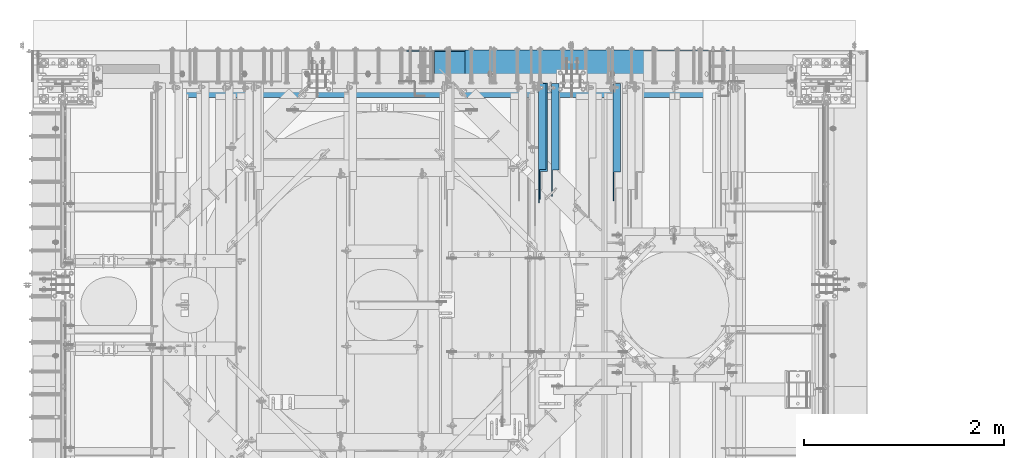
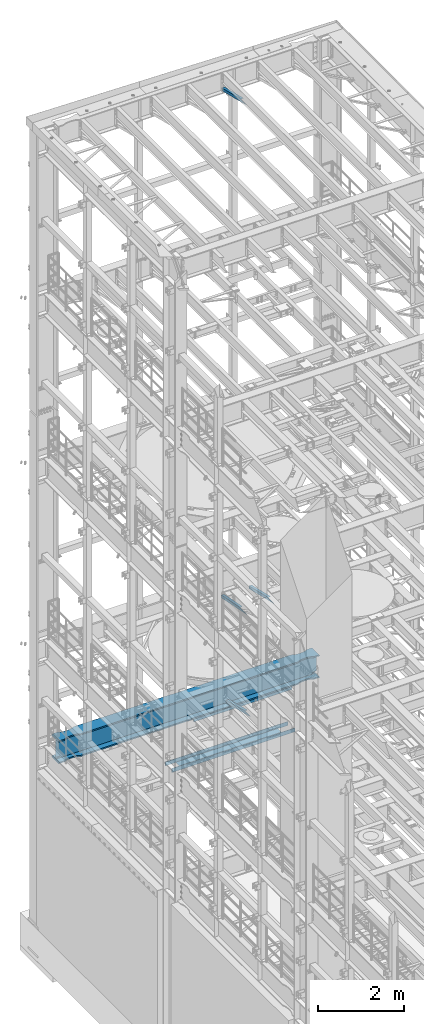
# One storey, part 1068 of 1876: 7 beams, 7 elements without a shape of their own.
"""IFC2X3 building model written with IfcOpenShell, lengths in millimetres."""

from ifc_helpers import new_model, si_unit, frame, origin_with_axes, place, context, subcontext, project, spatial, faceted_brep, material, type_object, element, aggregate, save


model = new_model("IFC2X3")

# Units and contexts
model_context = context("Model", 3, precision=1e-05, world=origin_with_axes())
body_context = subcontext(model_context, "Body", "Model", "MODEL_VIEW")
ifc_project = project(units=[si_unit("LENGTHUNIT", "METRE", prefix="MILLI"), si_unit("AREAUNIT", "SQUARE_METRE"), si_unit("VOLUMEUNIT", "CUBIC_METRE"), si_unit("MASSUNIT", "GRAM", prefix="KILO"), si_unit("TIMEUNIT", "SECOND"), si_unit("PLANEANGLEUNIT", "RADIAN"), si_unit("SOLIDANGLEUNIT", "STERADIAN"), si_unit("THERMODYNAMICTEMPERATUREUNIT", "DEGREE_CELSIUS"), si_unit("LUMINOUSINTENSITYUNIT", "LUMEN")], contexts=[model_context])

# Site, building, storey
site_placement = place(None, origin_with_axes())
site = spatial("IfcSite", under=ifc_project, at=site_placement, CompositionType="ELEMENT")
building_placement = place(site_placement, origin_with_axes())
building = spatial("IfcBuilding", under=site, at=building_placement, Name="Undefined", CompositionType="ELEMENT")
storey_placement = place(building_placement, origin_with_axes())
storey = spatial("IfcBuildingStorey", under=building, at=storey_placement, Name="Undefined", CompositionType="ELEMENT", Elevation=0.0)

# Assembly, beam
assembly_1_placement = place(storey_placement, origin_with_axes())
assembly_1 = element("IfcElementAssembly", 1, at=assembly_1_placement, inside=storey, AssemblyPlace="NOTDEFINED", PredefinedType="RIGID_FRAME")
ifc_material_1 = material(Name="STEEL/A36")
beam_type_1 = type_object("IfcBeamType", Name="L3X3X3/8", PredefinedType="NOTDEFINED")
beam_1_placement = place(assembly_1_placement, frame((4914.90000009537, 12830.5843372416, 4789.15168871849), z_axis=(1.0, 0.0, 0.0), x_axis=(0.0, 0.967147277703794, -0.254216724922142)))
beam_1 = element("IfcBeam", 2, at=beam_1_placement, type_object=beam_type_1, material=ifc_material_1, ObjectType="L3X3X3/8", context=body_context, shape_type="Brep", body=[
    faceted_brep([(24.9786869882064, 38.1000000000076, -38.1000000000004), (24.9786869882064, 38.1000000000076, 38.1000000000004), (881.684520949349, 38.1000000001804, 38.1000000000004), (881.684520949349, 38.1000000001804, -38.1000000000004), (-11.2584166993365, 28.5749999999989, 38.1000000000004), (881.696433462228, 28.5750000001808, 38.1000000000004), (-11.2584166993365, 28.5749999999989, -28.5749999999998), (881.696433462228, 28.5750000001808, -28.5749999999998), (-264.91814251215, -38.1000000000549, -28.5749999999998), (881.779821052378, -38.0999999998203, -28.5749999999998), (-264.91814251215, -38.1000000000549, -38.1000000000004), (881.779821052378, -38.0999999998203, -38.1000000000004)], [[[0, 1, 2, 3]], [[1, 4, 5, 2]], [[4, 6, 7, 5]], [[6, 8, 9, 7]], [[8, 10, 11, 9]], [[10, 0, 3, 11]], [[5, 7, 9, 11, 3, 2]], [[10, 8, 6, 4, 1, 0]]]),
])
aggregate(assembly_1, [beam_1])

assembly_2_placement = place(storey_placement, origin_with_axes())
assembly_2 = element("IfcElementAssembly", 3, at=assembly_2_placement, inside=storey, AssemblyPlace="NOTDEFINED", PredefinedType="RIGID_FRAME")
beam_2_placement = place(assembly_2_placement, frame((4797.425, 12840.8509533049, 22213.431722183), z_axis=(1.0, 0.0, 0.0), x_axis=(0.0, 0.970296005691371, -0.241920774923053)))
beam_2 = element("IfcBeam", 4, at=beam_2_placement, type_object=beam_type_1, material=ifc_material_1, ObjectType="L3X3X3/8", context=body_context, shape_type="Brep", body=[
    faceted_brep([(0.0, 38.1000000000004, -38.1), (0.0, 38.1000000000004, 38.1), (871.989692018896, 38.1000000003733, 38.1000000000004), (871.989692018896, 38.1000000003733, -38.1000000000004), (-38.2028763666676, 28.5750000000298, 38.1000000000004), (871.9896920189, 28.5750000003572, 38.1000000000004), (-38.2028763666676, 28.5750000000298, -28.5749999999998), (871.9896920189, 28.5750000003572, -28.5749999999998), (-305.623010913256, -38.1000000001623, -28.5749999999998), (871.989692018928, -38.0999999997366, -28.5749999999998), (-305.623010913256, -38.1000000001623, -38.1000000000004), (871.989692018928, -38.0999999997366, -38.1000000000004)], [[[0, 1, 2, 3]], [[1, 4, 5, 2]], [[4, 6, 7, 5]], [[6, 8, 9, 7]], [[8, 10, 11, 9]], [[10, 0, 3, 11]], [[5, 7, 9, 11, 3, 2]], [[10, 8, 6, 4, 1, 0]]]),
])
aggregate(assembly_2, [beam_2])

assembly_3_placement = place(storey_placement, origin_with_axes())
assembly_3 = element("IfcElementAssembly", 5, at=assembly_3_placement, inside=storey, AssemblyPlace="NOTDEFINED", PredefinedType="RIGID_FRAME")
beam_3_placement = place(assembly_3_placement, frame((4783.93125, 12872.1857065717, 7766.82651976129), z_axis=(1.0, 0.0, 0.0), x_axis=(0.0, 0.979618903835331, -0.200865136966236)))
beam_3 = element("IfcBeam", 6, at=beam_3_placement, type_object=beam_type_1, material=ifc_material_1, ObjectType="L3X3X3/8", context=body_context, shape_type="Brep", body=[
    faceted_brep([(0.0, 38.1000000000004, -38.1), (0.0, 38.1000000000004, 38.1), (830.060116754295, 38.1000000001277, 38.0999999999999), (830.060116754295, 38.1000000001277, -38.0999999999999), (-46.4534075084157, 28.5749999999953, 38.0999999999999), (830.060116754288, 28.5750000001281, 38.0999999999999), (-46.4534075084157, 28.5749999999953, -28.575), (830.060116754288, 28.5750000001281, -28.575), (-371.627259972192, -38.1000000000549, -28.575), (830.060116754226, -38.0999999998749, -28.575), (-371.627259972192, -38.1000000000549, -38.0999999999999), (830.060116754226, -38.0999999998749, -38.0999999999999)], [[[0, 1, 2, 3]], [[1, 4, 5, 2]], [[4, 6, 7, 5]], [[6, 8, 9, 7]], [[8, 10, 11, 9]], [[10, 0, 3, 11]], [[5, 7, 9, 11, 3, 2]], [[10, 8, 6, 4, 1, 0]]]),
])
aggregate(assembly_3, [beam_3])

assembly_4_placement = place(storey_placement, origin_with_axes())
assembly_4 = element("IfcElementAssembly", 7, at=assembly_4_placement, inside=storey, AssemblyPlace="NOTDEFINED", PredefinedType="RIGID_FRAME")
beam_4_placement = place(assembly_4_placement, frame((5527.675, 12840.0279763324, 7802.01022141264), z_axis=(1.0, 0.0, 0.0), x_axis=(0.0, 0.972828834357878, -0.231525504085172)))
beam_4 = element("IfcBeam", 8, at=beam_4_placement, type_object=beam_type_1, material=ifc_material_1, ObjectType="L3X3X3/8", context=body_context, shape_type="Brep", body=[
    faceted_brep([(0.0, 38.1000000000004, -38.1), (0.0, 38.1000000000004, 38.1), (867.661726641916, 38.1000000002095, 38.1000000000004), (867.661726641916, 38.1000000002095, -38.1000000000004), (-40.0223495126247, 28.5749999999825, 38.1000000000004), (867.584845052073, 28.5750000002117, 38.1000000000004), (-40.0223495126247, 28.5749999999825, -28.5749999999998), (867.584845052073, 28.5750000002117, -28.5749999999998), (-320.178796151862, -38.1000000000677, -28.5749999999998), (867.04667392318, -38.0999999997694, -28.5749999999998), (-320.178796151862, -38.1000000000677, -38.1000000000004), (867.04667392318, -38.0999999997694, -38.1000000000004)], [[[0, 1, 2, 3]], [[1, 4, 5, 2]], [[4, 6, 7, 5]], [[6, 8, 9, 7]], [[8, 10, 11, 9]], [[10, 0, 3, 11]], [[5, 7, 9, 11, 3, 2]], [[10, 8, 6, 4, 1, 0]]]),
])
aggregate(assembly_4, [beam_4])

assembly_5_placement = place(storey_placement, origin_with_axes())
assembly_5 = element("IfcElementAssembly", 9, at=assembly_5_placement, inside=storey, Name="BENT PLATE", AssemblyPlace="NOTDEFINED", PredefinedType="RIGID_FRAME")
beam_type_2 = type_object("IfcBeamType", PredefinedType="NOTDEFINED")
beam_5_placement = place(assembly_5_placement, frame((5334.00001220702, 14017.625, 4279.90000305175), z_axis=(1.0, 0.0, 0.0), x_axis=(0.0, 0.0, 1.0)))
beam_5 = element("IfcBeam", 10, at=beam_5_placement, type_object=beam_type_2, material=ifc_material_1, Name="BENT PLATE", context=body_context, shape_type="Brep", body=[
    faceted_brep([(0.0, -6.35000000000036, -1320.8), (0.0, -6.35000000000036, 1320.8), (0.0, 6.35000000000036, 1320.8), (0.0, 6.35000000000036, -1320.8), (190.499996948253, 6.35000000000218, 1320.8), (190.499996948253, 6.35000000000218, -1320.8), (203.199996948254, -6.34999999999854, -1320.8), (203.199996948254, -6.34999999999854, 1320.8), (190.499996948253, 303.212481689452, 1320.8), (190.499996948253, 303.212481689452, -1320.8), (203.199996948254, 315.912481689453, -1320.8), (203.199996948254, 315.912481689453, 1320.8), (2.45563569478691e-11, 303.212481689452, 1320.8), (2.45563569478691e-11, 303.212481689452, -1320.8), (2.45563569478691e-11, 315.912481689453, 1320.8), (2.45563569478691e-11, 315.912481689453, -1320.8)], [[[0, 1, 2, 3]], [[3, 2, 4, 5]], [[1, 0, 6, 7]], [[5, 4, 8, 9]], [[7, 6, 10, 11]], [[9, 8, 12, 13]], [[8, 4, 2, 1, 7, 11, 14, 12]], [[11, 10, 15, 14]], [[10, 6, 0, 3, 5, 9, 13, 15]], [[14, 15, 13, 12]]]),
])
aggregate(assembly_5, [beam_5])

assembly_6_placement = place(storey_placement, origin_with_axes())
assembly_6 = element("IfcElementAssembly", 11, at=assembly_6_placement, inside=storey, Name="BENT PLATE", AssemblyPlace="NOTDEFINED", PredefinedType="RIGID_FRAME")
beam_type_3 = type_object("IfcBeamType", PredefinedType="NOTDEFINED")
beam_6_placement = place(assembly_6_placement, frame((5079.99995117187, 14016.0375, 3159.12500000004), z_axis=(1.0, 0.0, 0.0), x_axis=(0.0, 0.0, -1.0)))
beam_6 = element("IfcBeam", 12, at=beam_6_placement, type_object=beam_type_3, material=ifc_material_1, Name="BENT PLATE", context=body_context, shape_type="Brep", body=[
    faceted_brep([(111.124998474122, -4.76250610351599, 1651.0), (101.599998474122, -4.76250000000073, 1651.0), (101.599998474122, -4.76250000000073, 1371.59995155207), (111.124998474122, -4.76249995652506, 1371.59995150444), (101.599998474122, -301.624987792969, 1371.59994502117), (111.124998474122, -301.624987749541, 1371.59994497354), (111.124998474122, -301.624993896485, 1650.99999990518), (101.599998474122, -301.624987792969, 1651.0), (0.0, -4.76250000000073, -1651.0), (0.0, -4.76250000000073, -1371.59995061689), (0.0, -4.76250000000073, 1371.59995206011), (0.0, -4.76250000000073, 1651.0), (0.0, 4.76250000000073, 1651.0), (0.0, 4.76250000000073, -1651.0), (111.124998474122, 4.76250000000073, 1651.0), (111.124998474122, 4.76250000000073, -1651.0), (111.124998474122, -4.76250606001486, -1651.0), (101.599998474122, -4.76250000000073, -1651.0), (111.124998474122, -4.76251220700578, -1371.5999511725), (101.599998474122, -4.76250000000073, -1371.59995112488), (111.124998474122, -301.624999999975, -1371.5999512195), (101.599998474122, -301.624987792969, -1371.59995117187), (111.124998474122, -301.624993853029, -1651.0), (101.599998474122, -301.624987792969, -1651.0), (111.124998474122, -311.149987792971, -1651.0), (0.0, -311.149987792971, -1651.0), (0.0, -301.624987792969, -1651.0), (0.0, -301.624987792969, 1651.0), (0.0, -311.149987792971, 1651.0), (111.124998474122, -311.149987792971, 1651.0), (0.0, -301.624987792969, 1371.59994552921), (0.0, -301.624987792969, -1371.59995066388)], [[[0, 1, 2, 3]], [[3, 2, 4, 5]], [[6, 5, 4, 7]], [[8, 9, 10, 11, 12, 13]], [[13, 12, 14, 15]], [[8, 13, 15, 16, 17]], [[18, 19, 17, 16]], [[20, 21, 19, 18]], [[22, 23, 21, 20]], [[24, 25, 26, 23, 22]], [[27, 28, 29, 6, 7]], [[24, 29, 28, 25]], [[27, 30, 31, 26, 25, 28]], [[7, 4, 21, 23, 26, 31, 30, 27]], [[19, 21, 4, 2]], [[11, 10, 9, 8, 17, 19, 2, 1]], [[14, 12, 11, 1, 0]], [[29, 24, 22, 20, 18, 16, 15, 14, 0, 3, 5, 6]]]),
])
aggregate(assembly_6, [beam_6])

assembly_7_placement = place(storey_placement, origin_with_axes())
assembly_7 = element("IfcElementAssembly", 13, at=assembly_7_placement, inside=storey, Name="BEAM", AssemblyPlace="NOTDEFINED", PredefinedType="RIGID_FRAME")
ifc_material_2 = material(Name="STEEL/A992")
beam_type_4 = type_object("IfcBeamType", Name="W24X192", PredefinedType="NOTDEFINED")
beam_7_placement = place(assembly_7_placement, frame((0.0, 13716.0, 4806.95), z_axis=(0.0, 0.0, 1.0), x_axis=(1.0, 0.0, 0.0)))
beam_7 = element("IfcBeam", 14, at=beam_7_placement, type_object=beam_type_4, material=ifc_material_2, Name="BEAM", ObjectType="W24X192", context=body_context, shape_type="Brep", body=[
    faceted_brep([(7305.675, 10.3187500000004, 234.9495), (7318.375, -10.3187500000004, 234.9495), (7318.375, -10.3187500000004, -234.9495), (7305.675, 10.3187500000004, -234.9495), (314.325, 10.3187500000004, -234.9495), (301.625, -10.3187500000004, -234.9495), (301.625, -10.3187500000004, 234.9495), (314.325, 10.3187500000004, 234.9495), (7318.375, -165.1, 287.3375), (7318.375, -10.3187500000004, 287.3375), (7318.375, 10.3187500000004, 287.3375), (7318.375, 165.1, 287.3375), (7297.29441686758, 165.10000015544, 323.85), (7297.29441686758, -165.10000015544, 323.85), (7162.79999999997, 165.100001147153, 323.85), (7162.79999999997, 165.1, 287.3375), (7106.74278259149, 137.743354635527, 287.3375), (7106.74278259149, 137.743354635527, 323.85), (7106.31195150567, 137.548767822031, 287.3375), (7106.31195150567, 137.548767822031, 323.85), (7105.87030058721, 137.380173875744, 287.3375), (7105.87030058721, 137.380173875744, 323.85), (7105.41939640416, 137.238170811695, 287.3375), (7105.41939640416, 137.238170811695, 323.85), (7104.96083834654, 137.123262325114, 287.3375), (7104.96083834654, 137.123262325114, 323.85), (7027.22388047199, 120.086541102203, 287.3375), (7027.22388047199, 120.086541102203, 323.85), (6946.89999542258, 114.300000048446, 287.3375), (6946.89999542258, 114.300000048446, 323.85), (6866.57611029489, 120.086540015548, 287.3375), (6866.57611029489, 120.086540015548, 323.85), (6787.91106783742, 137.326657821507, 287.3375), (6787.91106783742, 137.326657821507, 323.85), (6731.00000871489, 165.1, 287.3375), (6731.00000871489, 165.100000403941, 323.85), (888.999990590519, 165.1, 287.3375), (888.999990590519, 165.100004421514, 323.85), (832.088931467987, 137.326657821507, 287.3375), (832.088931467987, 137.326657821507, 323.85), (753.423889010533, 120.086540015548, 287.3375), (753.423889010533, 120.086540015548, 323.85), (673.100003882856, 114.300000048446, 287.3375), (673.100003882856, 114.300000048446, 323.85), (592.776118833464, 120.086541102203, 287.3375), (592.776118833464, 120.086541102203, 323.85), (515.039160958935, 137.123262325114, 287.3375), (515.039160958935, 137.123262325114, 323.85), (514.580602901315, 137.238170811695, 287.3375), (514.580602901315, 137.238170811695, 323.85), (514.12969871826, 137.380173875744, 287.3375), (514.12969871826, 137.380173875744, 323.85), (513.688047799806, 137.548767822031, 287.3375), (513.688047799806, 137.548767822031, 323.85), (513.257216713985, 137.743354635527, 287.3375), (513.257216713985, 137.743354635527, 323.85), (457.199999305522, 165.1, 287.3375), (457.199999305522, 165.1, 323.85), (301.625, 165.1, 287.3375), (322.705583132423, 165.1, 323.85), (7162.79999999997, 165.100001147153, -287.3375), (7162.79999999997, 165.1, -323.85), (7106.74278259149, 137.743354635527, -323.85), (7106.74278259149, 137.743354635527, -287.3375), (7106.31195150567, 137.548767822031, -323.85), (7106.31195150567, 137.548767822031, -287.3375), (7105.87030058721, 137.380173875744, -323.85), (7105.87030058721, 137.380173875744, -287.3375), (7105.41939640416, 137.238170811695, -323.85), (7105.41939640416, 137.238170811695, -287.3375), (7104.96083834654, 137.123262325114, -323.85), (7104.96083834654, 137.123262325114, -287.3375), (7027.22388047199, 120.086541102203, -323.85), (7027.22388047199, 120.086541102203, -287.3375), (6946.89999542258, 114.300000048446, -323.85), (6946.89999542258, 114.300000048446, -287.3375), (6866.57611029489, 120.086540015548, -323.85), (6866.57611029489, 120.086540015548, -287.3375), (6787.91106783742, 137.326657821507, -323.85), (6787.91106783742, 137.326657821507, -287.3375), (6731.00000871489, 165.1, -323.85), (6731.00000871489, 165.100000403941, -287.3375), (888.999990590519, 165.1, -323.85), (888.999990590519, 165.100004421514, -287.337500000001), (832.088931467987, 137.326657821507, -323.85), (832.088931467987, 137.326657821507, -287.3375), (753.423889010533, 120.086540015548, -323.85), (753.423889010533, 120.086540015548, -287.3375), (673.100003882856, 114.300000048446, -323.85), (673.100003882856, 114.300000048446, -287.3375), (592.776118833464, 120.086541102203, -323.85), (592.776118833464, 120.086541102203, -287.3375), (515.039160958935, 137.123262325114, -323.85), (515.039160958935, 137.123262325114, -287.3375), (514.580602901315, 137.238170811695, -323.85), (514.580602901315, 137.238170811695, -287.3375), (514.12969871826, 137.380173875744, -323.85), (514.12969871826, 137.380173875744, -287.3375), (513.688047799806, 137.548767822031, -323.85), (513.688047799806, 137.548767822031, -287.3375), (513.257216713985, 137.743354635527, -323.85), (513.257216713985, 137.743354635527, -287.3375), (457.199999305522, 165.1, -323.85), (457.199999305522, 165.1, -287.3375), (301.625, 165.1, -323.85), (322.705590767972, 165.1, -287.3375), (7162.79999999997, -165.100001147153, -287.3375), (7106.74278259149, -137.743354635527, -287.3375), (7106.74278259149, -137.743354635527, -323.85), (7162.79999999997, -165.1, -323.85), (7106.31195150567, -137.548767822031, -287.3375), (7106.31195150567, -137.548767822031, -323.85), (7105.87030058721, -137.380173875744, -287.3375), (7105.87030058721, -137.380173875744, -323.85), (7105.41939640416, -137.238170811695, -287.3375), (7105.41939640416, -137.238170811695, -323.85), (7104.96083834654, -137.123262325114, -287.3375), (7104.96083834654, -137.123262325114, -323.85), (7027.22388047199, -120.086541102203, -287.3375), (7027.22388047199, -120.086541102203, -323.85), (6946.89999542258, -114.300000048446, -287.3375), (6946.89999542258, -114.300000048446, -323.85), (6866.57611029489, -120.086540015548, -287.3375), (6866.57611029489, -120.086540015548, -323.85), (6787.91106783742, -137.326657821507, -287.3375), (6787.91106783742, -137.326657821507, -323.85), (6731.00000871489, -165.100000403941, -287.3375), (6731.00000871489, -165.1, -323.85), (888.999990590519, -165.100004421514, -287.3375), (888.999990590519, -165.1, -323.85), (832.088931467987, -137.326657821507, -287.3375), (832.088931467987, -137.326657821507, -323.85), (753.423889010533, -120.086540015548, -287.3375), (753.423889010533, -120.086540015548, -323.85), (673.100003882856, -114.300000048446, -287.3375), (673.100003882856, -114.300000048446, -323.85), (592.776118833464, -120.086541102203, -287.3375), (592.776118833464, -120.086541102203, -323.85), (515.039160958935, -137.123262325114, -287.3375), (515.039160958935, -137.123262325114, -323.85), (514.580602901315, -137.238170811695, -287.3375), (514.580602901315, -137.238170811695, -323.85), (514.12969871826, -137.380173875744, -287.3375), (514.12969871826, -137.380173875744, -323.85), (513.688047799806, -137.548767822031, -287.3375), (513.688047799806, -137.548767822031, -323.85), (513.257216713985, -137.743354635527, -287.3375), (513.257216713985, -137.743354635527, -323.85), (457.199999305522, -165.1, -287.3375), (457.199999305522, -165.1, -323.85), (322.705590767972, -165.1, -287.3375), (301.625, -165.1, -323.85), (322.934794701563, -10.3187500000004, -286.94050112915), (322.934794701563, 10.3187500000004, -286.94050112915), (322.705590767971, 10.3187500000004, -287.3375), (322.705590767971, -10.3187500000004, -287.3375), (346.976999328614, -10.3187500000004, -286.94050112915), (346.976999328614, 10.3187500000004, -286.94050112915), (420.061565494404, -10.3187500000004, -253.118738544442), (420.061565494404, 10.3187500000004, -253.118738544442), (423.945404365968, -10.3187500000004, -249.819149292641), (423.945404365968, 10.3187500000004, -249.819149292641), (425.572284211328, -10.3187500000004, -244.98957834072), (425.572284211328, 10.3187500000004, -244.98957834072), (424.476487622709, -10.3187500000004, -240.012558806176), (424.476487622709, 10.3187500000004, -240.012558806176), (420.97170190047, -10.3187500000004, -236.312833052547), (420.97170190047, 10.3187500000004, -236.312833052547), (416.061221618592, -10.3187500000004, -234.9495), (416.061221618592, 10.3187500000004, -234.9495), (415.15921904546, -10.3187500000004, 234.949499999999), (415.15921904546, 10.3187500000004, 234.949499999999), (420.069699306212, -10.3187500000004, 236.312833039836), (420.069699306212, 10.3187500000004, 236.312833039836), (423.574485026478, -10.3187500000004, 240.012558762611), (423.574485026478, 10.3187500000004, 240.012558762611), (424.670281642195, -10.3187500000004, 244.989578266865), (424.670281642195, 10.3187500000004, 244.989578266865), (423.043401848172, -10.3187500000004, 249.819149211012), (423.043401848172, 10.3187500000004, 249.819149211012), (419.159563033145, -10.3187500000004, 253.11873849267), (419.159563033145, 10.3187500000004, 253.11873849267), (346.074999237061, -10.3187500000004, 286.94050112915), (346.074999237061, 10.3187500000004, 286.94050112915), (301.625, -10.3187500000004, 286.94050112915), (301.625, 10.3187500000004, 286.94050112915), (301.625, -10.3187500000004, 287.3375), (301.625, 10.3187500000004, 287.3375), (322.705583132423, -165.1, 323.85), (301.625, -165.1, 287.3375), (457.199999305522, -165.1, 287.3375), (457.199999305522, -165.1, 323.85), (513.257216713985, -137.743354635527, 287.3375), (513.257216713985, -137.743354635527, 323.85), (513.688047799806, -137.548767822031, 287.3375), (513.688047799806, -137.548767822031, 323.85), (514.12969871826, -137.380173875744, 287.3375), (514.12969871826, -137.380173875744, 323.85), (514.580602901315, -137.238170811695, 287.3375), (514.580602901315, -137.238170811695, 323.85), (515.039160958935, -137.123262325114, 287.3375), (515.039160958935, -137.123262325114, 323.85), (592.776118833464, -120.086541102203, 287.3375), (592.776118833464, -120.086541102203, 323.85), (673.100003882856, -114.300000048446, 287.3375), (673.100003882856, -114.300000048446, 323.85), (753.423889010533, -120.086540015548, 287.3375), (753.423889010533, -120.086540015548, 323.85), (832.088931467987, -137.326657821507, 287.3375), (832.088931467987, -137.326657821507, 323.85), (888.999990590519, -165.100004421514, 323.85), (888.999990590519, -165.1, 287.3375), (6731.00000871489, -165.1, 287.3375), (6731.00000871489, -165.100000403941, 323.85), (6787.91106783742, -137.326657821507, 287.3375), (6787.91106783742, -137.326657821507, 323.85), (6866.57611029489, -120.086540015548, 287.3375), (6866.57611029489, -120.086540015548, 323.85), (6946.89999542258, -114.300000048446, 287.3375), (6946.89999542258, -114.300000048446, 323.85), (7027.22388047199, -120.086541102203, 287.3375), (7027.22388047199, -120.086541102203, 323.85), (7104.96083834654, -137.123262325114, 287.3375), (7104.96083834654, -137.123262325114, 323.85), (7105.41939640416, -137.238170811695, 287.3375), (7105.41939640416, -137.238170811695, 323.85), (7105.87030058721, -137.380173875744, 287.3375), (7105.87030058721, -137.380173875744, 323.85), (7106.31195150567, -137.548767822031, 287.3375), (7106.31195150567, -137.548767822031, 323.85), (7106.74278259149, -137.743354635527, 287.3375), (7106.74278259149, -137.743354635527, 323.85), (7162.79999999997, -165.100001147153, 323.85), (7162.79999999997, -165.1, 287.3375), (7318.375, -10.3187500000004, 286.94050112915), (7318.375, 10.3187500000004, 286.94050112915), (7273.92500076294, -10.3187500000004, 286.94050112915), (7273.92500076294, 10.3187500000004, 286.94050112915), (7200.84043696685, -10.3187500000004, 253.118738492671), (7200.84043696685, 10.3187500000004, 253.118738492671), (7196.95659815183, -10.3187500000004, 249.819149211013), (7196.95659815183, 10.3187500000004, 249.819149211013), (7195.3297183578, -10.3187500000004, 244.989578266866), (7195.3297183578, 10.3187500000004, 244.989578266866), (7196.42551497352, -10.3187500000004, 240.012558762612), (7196.42551497352, 10.3187500000004, 240.012558762612), (7199.93030069379, -10.3187500000004, 236.312833039837), (7199.93030069379, 10.3187500000004, 236.312833039837), (7204.84078095454, -10.3187500000004, 234.9495), (7204.84078095454, 10.3187500000004, 234.9495), (7203.93877838141, -10.3187500000004, -234.9495), (7203.93877838141, 10.3187500000004, -234.9495), (7199.02829809953, -10.3187500000004, -236.312833052547), (7199.02829809953, 10.3187500000004, -236.312833052547), (7195.52351237729, -10.3187500000004, -240.012558806176), (7195.52351237729, 10.3187500000004, -240.012558806176), (7194.42771578867, -10.3187500000004, -244.98957834072), (7194.42771578867, 10.3187500000004, -244.98957834072), (7196.05459563403, -10.3187500000004, -249.819149292641), (7196.05459563403, 10.3187500000004, -249.819149292641), (7199.93843450559, -10.3187500000004, -253.118738544442), (7199.93843450559, 10.3187500000004, -253.118738544442), (7273.02300067138, -10.3187500000004, -286.94050112915), (7273.02300067138, 10.3187500000004, -286.94050112915), (7297.06520529844, -10.3187500000004, -286.94050112915), (7297.06520529844, 10.3187500000004, -286.94050112915), (7297.29440923203, 10.3187500000004, -287.3375), (7297.29440923203, 165.10000015544, -287.3375), (7318.375, 165.1, -323.85), (7318.375, -165.1, -323.85), (7297.29440923203, -165.10000015544, -287.3375), (7297.29440923203, -10.3187500000004, -287.3375)], [[[0, 1, 2, 3]], [[4, 5, 6, 7]], [[8, 9, 10, 11, 12, 13]], [[14, 15, 16, 17]], [[17, 16, 18, 19]], [[19, 18, 20, 21]], [[21, 20, 22, 23]], [[23, 22, 24, 25]], [[25, 24, 26, 27]], [[27, 26, 28, 29]], [[29, 28, 30, 31]], [[31, 30, 32, 33]], [[33, 32, 34, 35]], [[36, 37, 35, 34]], [[37, 36, 38, 39]], [[39, 38, 40, 41]], [[41, 40, 42, 43]], [[43, 42, 44, 45]], [[45, 44, 46, 47]], [[47, 46, 48, 49]], [[49, 48, 50, 51]], [[51, 50, 52, 53]], [[53, 52, 54, 55]], [[55, 54, 56, 57]], [[57, 56, 58, 59]], [[60, 61, 62, 63]], [[63, 62, 64, 65]], [[65, 64, 66, 67]], [[67, 66, 68, 69]], [[69, 68, 70, 71]], [[71, 70, 72, 73]], [[73, 72, 74, 75]], [[75, 74, 76, 77]], [[77, 76, 78, 79]], [[79, 78, 80, 81]], [[82, 83, 81, 80]], [[83, 82, 84, 85]], [[85, 84, 86, 87]], [[87, 86, 88, 89]], [[89, 88, 90, 91]], [[91, 90, 92, 93]], [[93, 92, 94, 95]], [[95, 94, 96, 97]], [[97, 96, 98, 99]], [[99, 98, 100, 101]], [[101, 100, 102, 103]], [[103, 102, 104, 105]], [[106, 107, 108, 109]], [[110, 111, 108, 107]], [[112, 113, 111, 110]], [[114, 115, 113, 112]], [[116, 117, 115, 114]], [[118, 119, 117, 116]], [[120, 121, 119, 118]], [[122, 123, 121, 120]], [[124, 125, 123, 122]], [[126, 127, 125, 124]], [[128, 129, 127, 126]], [[128, 130, 131, 129]], [[132, 133, 131, 130]], [[134, 135, 133, 132]], [[136, 137, 135, 134]], [[138, 139, 137, 136]], [[140, 141, 139, 138]], [[142, 143, 141, 140]], [[144, 145, 143, 142]], [[146, 147, 145, 144]], [[148, 149, 147, 146]], [[149, 148, 150, 151]], [[152, 153, 154, 105, 104, 151, 150, 155]], [[156, 157, 153, 152]], [[158, 159, 157, 156]], [[160, 161, 159, 158]], [[162, 163, 161, 160]], [[164, 165, 163, 162]], [[166, 167, 165, 164]], [[168, 169, 167, 166]], [[169, 168, 5, 4]], [[170, 171, 7, 6]], [[172, 173, 171, 170]], [[174, 175, 173, 172]], [[176, 177, 175, 174]], [[178, 179, 177, 176]], [[180, 181, 179, 178]], [[182, 183, 181, 180]], [[183, 182, 184, 185]], [[185, 184, 186, 187]], [[188, 59, 58, 187, 186, 189]], [[190, 191, 188, 189]], [[191, 190, 192, 193]], [[193, 192, 194, 195]], [[195, 194, 196, 197]], [[197, 196, 198, 199]], [[199, 198, 200, 201]], [[201, 200, 202, 203]], [[203, 202, 204, 205]], [[205, 204, 206, 207]], [[207, 206, 208, 209]], [[210, 209, 208, 211]], [[210, 211, 212, 213]], [[213, 212, 214, 215]], [[215, 214, 216, 217]], [[217, 216, 218, 219]], [[219, 218, 220, 221]], [[221, 220, 222, 223]], [[223, 222, 224, 225]], [[225, 224, 226, 227]], [[227, 226, 228, 229]], [[229, 228, 230, 231]], [[232, 231, 230, 233]], [[232, 233, 8, 13]], [[14, 17, 19, 21, 23, 25, 27, 29, 31, 33, 35, 37, 39, 41, 43, 45, 47, 49, 51, 53, 55, 57, 59, 188, 191, 193, 195, 197, 199, 201, 203, 205, 207, 209, 210, 213, 215, 217, 219, 221, 223, 225, 227, 229, 231, 232, 13, 12]], [[15, 14, 12, 11]], [[187, 58, 56, 54, 52, 50, 48, 46, 44, 42, 40, 38, 36, 34, 32, 30, 28, 26, 24, 22, 20, 18, 16, 15, 11, 10]], [[234, 235, 10, 9]], [[236, 237, 235, 234]], [[238, 239, 237, 236]], [[240, 241, 239, 238]], [[242, 243, 241, 240]], [[244, 245, 243, 242]], [[246, 247, 245, 244]], [[248, 249, 247, 246]], [[249, 248, 1, 0]], [[250, 251, 3, 2]], [[252, 253, 251, 250]], [[254, 255, 253, 252]], [[256, 257, 255, 254]], [[258, 259, 257, 256]], [[260, 261, 259, 258]], [[262, 263, 261, 260]], [[263, 262, 264, 265]], [[251, 253, 255, 257, 259, 261, 263, 265, 266, 154, 153, 157, 159, 161, 163, 165, 167, 169, 4, 7, 171, 173, 175, 177, 179, 181, 183, 185, 187, 10, 235, 237, 239, 241, 243, 245, 247, 249, 0, 3]], [[60, 63, 65, 67, 69, 71, 73, 75, 77, 79, 81, 83, 85, 87, 89, 91, 93, 95, 97, 99, 101, 103, 105, 154, 266, 267]], [[61, 60, 267, 268]], [[109, 108, 111, 113, 115, 117, 119, 121, 123, 125, 127, 129, 131, 133, 135, 137, 139, 141, 143, 145, 147, 149, 151, 104, 102, 100, 98, 96, 94, 92, 90, 88, 86, 84, 82, 80, 78, 76, 74, 72, 70, 68, 66, 64, 62, 61, 268, 269]], [[106, 109, 269, 270]], [[155, 150, 148, 146, 144, 142, 140, 138, 136, 134, 132, 130, 128, 126, 124, 122, 120, 118, 116, 114, 112, 110, 107, 106, 270, 271]], [[269, 268, 267, 266, 265, 264, 271, 270]], [[262, 260, 258, 256, 254, 252, 250, 2, 1, 248, 246, 244, 242, 240, 238, 236, 234, 9, 186, 184, 182, 180, 178, 176, 174, 172, 170, 6, 5, 168, 166, 164, 162, 160, 158, 156, 152, 155, 271, 264]], [[233, 230, 228, 226, 224, 222, 220, 218, 216, 214, 212, 211, 208, 206, 204, 202, 200, 198, 196, 194, 192, 190, 189, 186, 9, 8]]]),
])
aggregate(assembly_7, [beam_7])

save(model, "model.ifc")
